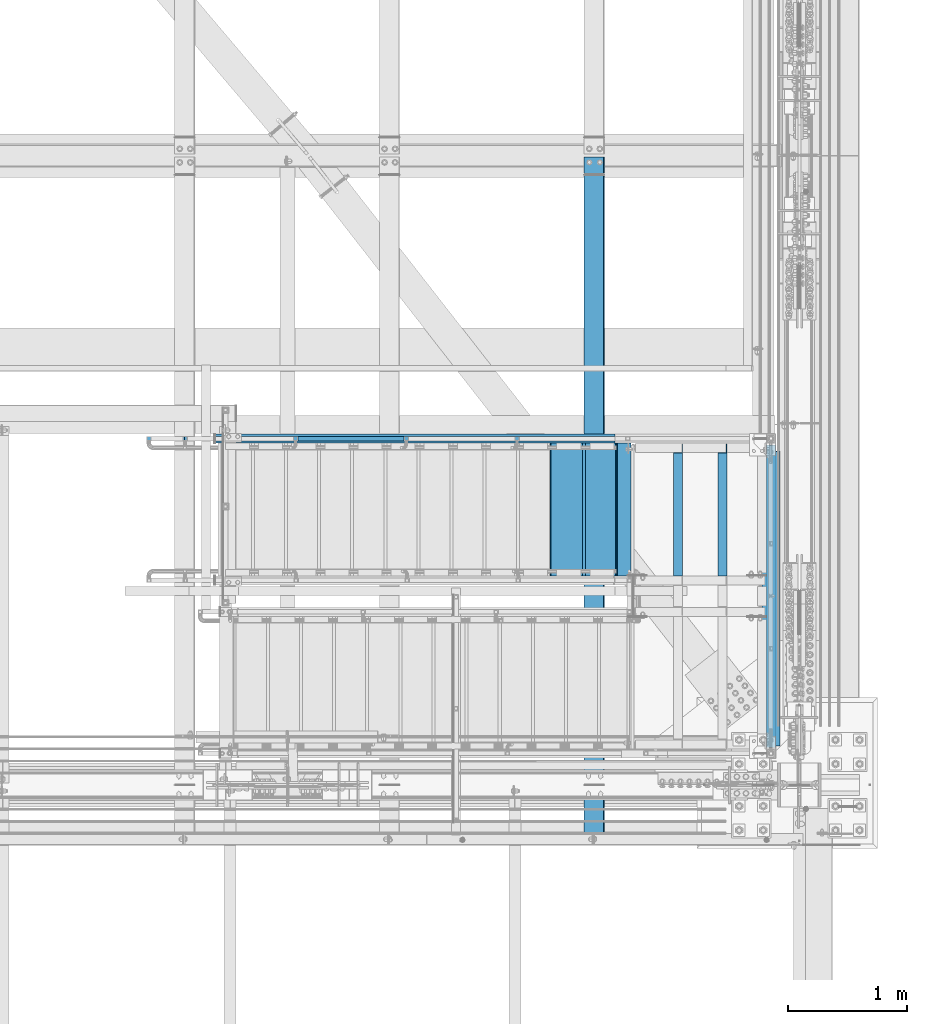
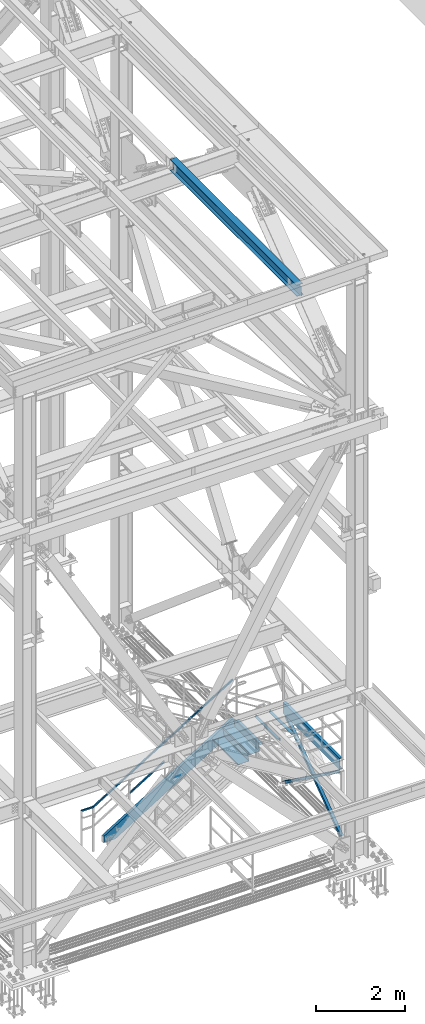
# One storey, part 1949 of 3843: 8 beams, 4 members, 8 elements without a shape of their own.
"""IFC2X3 building model written with IfcOpenShell, lengths in millimetres."""

from ifc_helpers import new_model, si_unit, frame, origin_with_axes, place, context, subcontext, project, spatial, faceted_brep, material, type_object, element, aggregate, save


model = new_model("IFC2X3")

# Units and contexts
model_context = context("Model", 3, precision=1e-05, world=origin_with_axes())
body_context = subcontext(model_context, "Body", "Model", "MODEL_VIEW")
ifc_project = project(units=[si_unit("LENGTHUNIT", "METRE", prefix="MILLI"), si_unit("AREAUNIT", "SQUARE_METRE"), si_unit("VOLUMEUNIT", "CUBIC_METRE"), si_unit("MASSUNIT", "GRAM", prefix="KILO"), si_unit("TIMEUNIT", "SECOND"), si_unit("PLANEANGLEUNIT", "RADIAN"), si_unit("SOLIDANGLEUNIT", "STERADIAN"), si_unit("THERMODYNAMICTEMPERATUREUNIT", "DEGREE_CELSIUS"), si_unit("LUMINOUSINTENSITYUNIT", "LUMEN")], contexts=[model_context])

# Site, building, storey
site_placement = place(None, origin_with_axes())
site = spatial("IfcSite", under=ifc_project, at=site_placement, CompositionType="ELEMENT")
building_placement = place(site_placement, origin_with_axes())
building = spatial("IfcBuilding", under=site, at=building_placement, Name="Undefined", CompositionType="ELEMENT")
storey_placement = place(building_placement, origin_with_axes())
storey = spatial("IfcBuildingStorey", under=building, at=storey_placement, Name="Undefined", CompositionType="ELEMENT", Elevation=0.0)

# Assembly, beam, member
assembly_1_placement = place(storey_placement, origin_with_axes())
assembly_1 = element("IfcElementAssembly", 1, at=assembly_1_placement, inside=storey, Name="RAIL", AssemblyPlace="NOTDEFINED", PredefinedType="RIGID_FRAME")
ifc_material_1 = material()
beam_type_1 = type_object("IfcBeamType", Name="HSS1-1/2X1-1/2X1/4", PredefinedType="NOTDEFINED")
beam_1_placement = place(assembly_1_placement, frame((84099.3999999465, 17919.7, 33781.9999999847), z_axis=(0.524097425775922, 0.0, -0.851658316635875), x_axis=(-0.851658316635875, 0.0, -0.524097425775922)))
beam_1 = element("IfcBeam", 2, at=beam_1_placement, type_object=beam_type_1, material=ifc_material_1, Name="RAIL", ObjectType="HSS1-1/2X1-1/2X1/4", context=body_context, shape_type="Brep", body=[
    faceted_brep([(-5.39195355401171, -19.0499992350015, -19.0499992349942), (5.39195347770146, -19.0499992350015, 19.0499992349796), (5.39195347770146, 19.0499992350015, 19.0499992349796), (-5.39195355401171, 19.0499992350015, -19.0499992349942), (3.59463559381402, 12.6999993300014, 12.6999993299833), (3.59463559381402, -12.6999993300014, 12.6999993299833), (-3.59463567009516, -12.6999993300014, -12.6999993299978), (-3.59463567009516, 12.6999993300014, -12.6999993299978), (4270.24785764143, -19.0499992349996, 19.0499992372643), (4270.24785764143, 19.0499992349996, 19.0499992372643), (4259.4639506097, 19.0499992349996, -19.049999232695), (4259.4639506097, -19.0499992349996, -19.049999232695), (4261.26126849362, -12.6999993299996, -12.6999993277132), (4261.26126849362, 12.6999993299996, -12.6999993277132), (4268.45053975753, 12.6999993299996, 12.6999993322825), (4268.45053975753, -12.6999993299996, 12.6999993322825), (4530.68139334727, 19.0499992350015, -185.9530417606), (4530.68139334727, -19.0499992350015, -185.9530417606), (4518.20132390667, -19.0499992350015, -133.536750079667), (4518.20132390667, 19.0499992350015, -133.536750079667), (4528.60138172143, -12.6999993300014, -177.216992926999), (4528.60138172143, 12.6999993300014, -177.216992926999), (4520.28133553253, 12.6999993300014, -142.27279891328), (4520.28133553253, -12.6999993300014, -142.27279891328)], [[[0, 1, 2, 3], [4, 5, 6, 7]], [[2, 1, 8, 9]], [[0, 3, 10, 11]], [[7, 6, 12, 13]], [[5, 4, 14, 15]], [[11, 10, 16, 17]], [[8, 1, 0, 11, 17, 18]], [[9, 8, 18, 19]], [[10, 3, 2, 9, 19, 16]], [[13, 12, 20, 21]], [[14, 4, 7, 13, 21, 22]], [[15, 14, 22, 23]], [[12, 6, 5, 15, 23, 20]], [[19, 18, 17, 16], [22, 21, 20, 23]]]),
])
member_type_1 = type_object("IfcMemberType", Name="HSS1-1/2X1-1/2X1/4", PredefinedType="NOTDEFINED")
member_1_placement = place(assembly_1_placement, frame((81400.649999991, 17919.7, 31587.830768766), z_axis=(-0.524097425775922, 0.0, 0.851658316635875), x_axis=(0.851658316635872, 0.0, 0.524097425775926)))
member_1 = element("IfcMember", 3, at=member_1_placement, type_object=member_type_1, material=ifc_material_1, Name="RAIL", ObjectType="HSS1-1/2X1-1/2X1/4", context=body_context, shape_type="Brep", body=[
    faceted_brep([(1085.39309424335, -19.0499999999993, 19.0499992355599), (1061.94694133186, -19.0499992350015, -19.0499992344103), (1061.94694133186, 19.0499992350015, -19.0499992344103), (1085.39309424335, 19.0499992350015, 19.0499992355599), (1081.48540199296, -12.6999993300014, 12.6999993305635), (1081.48540199296, 12.6999993300014, 12.6999993305635), (1065.85463358223, 12.6999993300014, -12.6999993294176), (1065.85463358223, -12.6999993300014, -12.6999993294176), (10.6450480494532, 19.0499992350015, -19.0499992349796), (34.091200960931, 19.0499992350015, 19.0499992349942), (34.091200960931, -19.0499992350015, 19.0499992349942), (10.6450480494532, -19.0499992350015, -19.0499992349796), (30.1835087105574, 12.6999993300014, 12.6999993299978), (30.1835087105574, -12.6999993300014, 12.6999993299978), (14.5527402998268, -12.6999993300014, -12.6999993299833), (14.5527402998268, 12.6999993300014, -12.6999993299833)], [[[0, 1, 2, 3], [4, 5, 6, 7]], [[8, 9, 3, 2]], [[9, 10, 0, 3]], [[10, 11, 1, 0]], [[11, 8, 2, 1]], [[11, 10, 9, 8], [12, 13, 14, 15]], [[14, 13, 4, 7]], [[15, 14, 7, 6]], [[12, 15, 6, 5]], [[13, 12, 5, 4]]]),
])
aggregate(assembly_1, [member_1, beam_1])

# Assembly, beams
assembly_2_placement = place(storey_placement, origin_with_axes())
assembly_2 = element("IfcElementAssembly", 4, at=assembly_2_placement, inside=storey, Name="STAIR", AssemblyPlace="NOTDEFINED", PredefinedType="RIGID_FRAME")
ifc_material_2 = material(Name="STEEL/ASTM A1011")
beam_type_2 = type_object("IfcBeamType", PredefinedType="NOTDEFINED")
beam_2_placement = place(assembly_2_placement, frame((84229.5749999933, 17322.7999999328, 32665.9875000002), z_axis=(0.0, -1.0, 0.0), x_axis=(-1.0, 0.0, 0.0)))
beam_2 = element("IfcBeam", 5, at=beam_2_placement, type_object=beam_type_2, material=ifc_material_2, Name="TREAD", context=body_context, shape_type="Brep", body=[
    faceted_brep([(0.0, -1.58750000000146, -558.799999999999), (0.0, -1.58750000000146, 558.799999999999), (0.0, 1.58750000000146, 558.799999999999), (0.0, 1.58750000000146, -558.799999999999), (118.955406534296, 1.58750000000509, 558.799999999999), (118.955406534296, 1.58750000000509, -558.799999999999), (116.251539361052, -1.58749999999782, -558.799999999999), (116.251539361052, -1.58749999999782, 558.799999999999), (124.953998182522, -35.5978063561452, 558.799999999999), (124.953998182522, -35.5978063561452, -558.799999999999), (121.81952036728, -36.1034483498916, 558.799999999999), (121.81952036728, -36.1034483498916, -558.799999999999)], [[[0, 1, 2, 3]], [[3, 2, 4, 5]], [[1, 0, 6, 7]], [[5, 4, 8, 9]], [[4, 2, 1, 7, 10, 8]], [[7, 6, 11, 10]], [[6, 0, 3, 5, 9, 11]], [[10, 11, 9, 8]]]),
])
beam_type_3 = type_object("IfcBeamType", PredefinedType="NOTDEFINED")
beam_3_placement = place(assembly_2_placement, frame((84124.8000000108, 17322.7999999328, 32713.6124999999), z_axis=(0.0, -1.0, 0.0), x_axis=(-1.0, 0.0, 0.0)))
beam_3 = element("IfcBeam", 6, at=beam_3_placement, type_object=beam_type_3, material=ifc_material_2, Name="TREAD", context=body_context, shape_type="Brep", body=[
    faceted_brep([(0.0, -1.58750000000146, -558.799999999999), (0.0, -1.58750000000146, 558.799999999999), (0.0, 1.58750000000146, 558.799999999999), (0.0, 1.58750000000146, -558.799999999999), (21.7215083258779, 1.58750000000146, 558.799999999999), (21.7215083258779, 1.58750000000146, -558.799999999999), (25.3999999999942, -1.58750000000146, -558.799999999999), (25.3999999999942, -1.58750000000146, 558.799999999999), (-11.1830371286633, 224.325961538467, 558.799999999999), (-11.1830371286633, 224.325961538467, -558.799999999999), (-7.50454545454704, 221.150961538464, -558.799999999999), (-7.50454545454704, 221.150961538464, 558.799999999999), (293.616962871325, 224.325961538467, 558.799999999999), (293.616962871325, 224.325961538467, -558.799999999999), (290.876539379024, 221.150961538464, -558.799999999999), (290.876539379024, 221.150961538464, 558.799999999999), (299.585432747743, 183.924011605752, 558.799999999999), (299.585432747743, 183.924011605752, -558.799999999999), (296.444520385252, 183.460013188564, 558.799999999999), (296.444520385252, 183.460013188564, -558.799999999999)], [[[0, 1, 2, 3]], [[3, 2, 4, 5]], [[1, 0, 6, 7]], [[5, 4, 8, 9]], [[7, 6, 10, 11]], [[9, 8, 12, 13]], [[11, 10, 14, 15]], [[13, 12, 16, 17]], [[12, 8, 4, 2, 1, 7, 11, 15, 18, 16]], [[15, 14, 19, 18]], [[14, 10, 6, 0, 3, 5, 9, 13, 17, 19]], [[18, 19, 17, 16]]]),
])
beam_4_placement = place(assembly_2_placement, frame((83845.4000000127, 17322.7999999318, 32541.6740384607), z_axis=(0.0, -1.0, 0.0), x_axis=(-1.0, 0.0, 0.0)))
beam_4 = element("IfcBeam", 7, at=beam_4_placement, type_object=beam_type_3, material=ifc_material_2, Name="TREAD", context=body_context, shape_type="Brep", body=[
    faceted_brep([(0.0, -1.58750000000146, -558.799999999999), (0.0, -1.58750000000146, 558.799999999999), (0.0, 1.58750000000146, 558.799999999999), (0.0, 1.58750000000146, -558.799999999999), (21.7215083258779, 1.58750000000146, 558.799999999999), (21.7215083258779, 1.58750000000146, -558.799999999999), (25.3999999999942, -1.58750000000146, -558.799999999999), (25.3999999999942, -1.58750000000146, 558.799999999999), (-11.1830371286633, 224.325961538467, 558.799999999999), (-11.1830371286633, 224.325961538467, -558.799999999999), (-7.50454545454704, 221.150961538464, -558.799999999999), (-7.50454545454704, 221.150961538464, 558.799999999999), (293.616962871325, 224.325961538467, 558.799999999999), (293.616962871325, 224.325961538467, -558.799999999999), (290.876539379024, 221.150961538464, -558.799999999999), (290.876539379024, 221.150961538464, 558.799999999999), (299.585432747743, 183.924011605752, 558.799999999999), (299.585432747743, 183.924011605752, -558.799999999999), (296.444520385252, 183.460013188564, 558.799999999999), (296.444520385252, 183.460013188564, -558.799999999999)], [[[0, 1, 2, 3]], [[3, 2, 4, 5]], [[1, 0, 6, 7]], [[5, 4, 8, 9]], [[7, 6, 10, 11]], [[9, 8, 12, 13]], [[11, 10, 14, 15]], [[13, 12, 16, 17]], [[12, 8, 4, 2, 1, 7, 11, 15, 18, 16]], [[15, 14, 19, 18]], [[14, 10, 6, 0, 3, 5, 9, 13, 17, 19]], [[18, 19, 17, 16]]]),
])

# Assembly, beam
assembly_3_placement = place(storey_placement, origin_with_axes())
assembly_3 = element("IfcElementAssembly", 8, at=assembly_3_placement, inside=storey, Name="STRINGER", AssemblyPlace="NOTDEFINED", PredefinedType="RIGID_FRAME")
ifc_material_3 = material(Name="STEEL/A36")
beam_type_4 = type_object("IfcBeamType", Name="C12X20.7", PredefinedType="NOTDEFINED")
beam_5_placement = place(assembly_3_placement, frame((85407.5000000149, 15227.3000000539, 32588.2), z_axis=(0.0, 0.0, 1.0), x_axis=(0.0, 1.0, 0.0)))
beam_5 = element("IfcBeam", 9, at=beam_5_placement, type_object=beam_type_4, material=ifc_material_3, Name="STRINGER", ObjectType="C12X20.7", context=body_context, shape_type="Brep", body=[
    faceted_brep([(88.8999999464759, 38.1000000000058, -152.400000000001), (88.8999999464759, 38.1000000000058, 152.400000000001), (2641.60000000041, 38.1000000000058, 152.400000000001), (2641.60000000041, 38.1000000000058, -152.400000000001), (88.8999999464759, -38.1000000000058, 152.400000000001), (2641.60000000041, -38.1000000000058, 152.400000000001), (88.8999999464759, -38.1000000000058, 146.047460000002), (2641.60000000041, -38.1000000000058, 146.047460000002), (88.8999999464759, 30.1625000000058, 134.6749275), (2641.60000000041, 30.1625000000058, 134.6749275), (88.8999999464759, 30.1625000000058, -134.6749275), (2641.60000000041, 30.1625000000058, -134.6749275), (88.8999999464759, -38.1000000000058, -146.047460000002), (2641.60000000041, -38.1000000000058, -146.047460000002), (88.8999999464759, -38.1000000000058, -152.400000000001), (2641.60000000041, -38.1000000000058, -152.400000000001)], [[[0, 1, 2, 3]], [[1, 4, 5, 2]], [[4, 6, 7, 5]], [[6, 8, 9, 7]], [[8, 10, 11, 9]], [[10, 12, 13, 11]], [[12, 14, 15, 13]], [[14, 0, 3, 15]], [[5, 7, 9, 11, 13, 15, 3, 2]], [[14, 12, 10, 8, 6, 4, 1, 0]]]),
])
aggregate(assembly_3, [beam_5])

# Member
member_type_2 = type_object("IfcMemberType", Name="C12X20.7", PredefinedType="NOTDEFINED")
member_2_placement = place(assembly_2_placement, frame((84172.0831760373, 17919.7000000062, 32610.8072725471), z_axis=(-0.524097425775922, 0.0, 0.851658316635875), x_axis=(-0.851658316635875, 0.0, -0.524097425775922)))
member_2 = element("IfcMember", 10, at=member_2_placement, type_object=member_type_2, material=ifc_material_3, Name="STAIR", ObjectType="C12X20.7", context=body_context, shape_type="Brep", body=[
    faceted_brep([(86.2712597135396, -38.0999999999985, -152.39999999988), (84.4732228755893, -38.0999999999985, -146.047459999883), (81.2543163632508, 30.1624999999985, -134.674927499889), (5.01694334564672, 30.1624999999985, 134.674927499867), (1.79803683332284, -38.0999999999985, 146.047459999862), (0.0, -38.0999999999985, 152.400000000001), (0.0, 38.0999999999985, 152.400000000001), (86.2712597135396, 38.0999999999985, -152.39999999988), (3793.78803882135, 38.0999999999985, -152.400000001866), (3793.78803882135, -38.0999999999985, -152.400000001866), (3804.11091631831, -38.0999999999985, -146.047460001873), (3822.59128162534, 30.1624999999985, -134.674927501905), (4049.06792565092, 30.1624999999985, 4.69531501628626), (3969.08047179269, 30.1624999999985, 134.674927497743), (3962.08199025219, -38.0999999999985, 146.047459997737), (3958.17273486643, -38.0999999999985, 152.399999997733), (3958.17273486643, 38.0999999999985, 152.399999997733), (4049.06792565092, 38.0999999999985, 4.69531501628626)], [[[0, 1, 2, 3, 4, 5, 6, 7]], [[0, 7, 8, 9]], [[1, 0, 9, 10]], [[2, 1, 10, 11]], [[3, 2, 11, 12, 13]], [[4, 3, 13, 14]], [[5, 4, 14, 15]], [[6, 5, 15, 16]], [[8, 7, 6, 16, 17]], [[11, 10, 9, 8, 17, 12]], [[16, 15, 14, 13, 12, 17]]]),
])

aggregate(assembly_2, [beam_2, beam_3, member_2, beam_4])

# Assembly, beam
assembly_4_placement = place(storey_placement, origin_with_axes())
assembly_4 = element("IfcElementAssembly", 11, at=assembly_4_placement, inside=storey, Name="BEAM", AssemblyPlace="NOTDEFINED", PredefinedType="RIGID_FRAME")
ifc_material_4 = material(Name="STEEL/A992")
beam_type_5 = type_object("IfcBeamType", Name="W12X26", PredefinedType="NOTDEFINED")
beam_6_placement = place(assembly_4_placement, frame((83918.3092623524, 14490.7000000001, 46575.5980897001), z_axis=(-0.0211520980073474, 0.0, 0.999776269347241), x_axis=(0.0, 1.0, 0.0)))
beam_6 = element("IfcBeam", 12, at=beam_6_placement, type_object=beam_type_5, material=ifc_material_4, Name="BEAM", ObjectType="W12X26", context=body_context, shape_type="Brep", body=[
    faceted_brep([(20.6374999998825, -3.17500000016298, -130.175000008305), (20.6374999998825, 3.1749999998865, -130.175000008305), (77.7875001906159, 3.1749999998865, -130.175000008334), (77.7875001906159, -3.17500000016298, -130.175000008334), (82.6475797086623, 3.1749999998865, -131.141729930918), (82.6475797086623, -3.17500000014843, -131.141729930918), (86.767756176816, 3.17499999987194, -133.894743831384), (86.767756176816, -3.17500000014843, -133.894743831377), (89.5207700772935, 3.17499999987194, -138.014920299524), (89.5207700772935, -3.17500000014843, -138.014920299516), (90.487499999881, -3.17500000014843, -142.874999817534), (90.487499999881, 3.17499999987194, -142.874999817541), (90.487499999881, 3.17499999987194, -146.049999999763), (90.487499999881, 82.5500000003231, -146.049999999828), (90.487499999881, 82.5500000003085, -155.574999999815), (90.487499999881, -82.5500000006286, -155.57499999967), (90.487499999881, -82.5500000006141, -146.04999999969), (90.487499999881, -3.17500000017753, -146.049999999756), (5803.89999999989, -82.5500000003231, 146.049999999843), (5803.89999999989, -82.5500000003085, 155.57499999983), (90.487499999881, -82.5500000003085, 155.574980215941), (90.487499999881, -82.5500000003231, 146.049999999843), (5803.89999999989, 82.5500000006141, 155.574999999684), (90.487499999881, 82.5500000006141, 155.574999999684), (5803.89999999989, 82.5500000006141, 146.049999999705), (90.487499999881, 82.5500000006141, 146.049999999705), (5803.89999999989, 3.17500000016298, 146.04999999977), (90.487499999881, 3.17500000016298, 146.04999999977), (77.7875001906159, -3.1749999998865, 130.174999990406), (77.7875001906159, 3.17500000014843, 130.174999990399), (20.6374999998825, 3.17500000014843, 130.174999990428), (20.6374999998825, -3.1749999998865, 130.174999990435), (82.6475797086623, -3.1749999998865, 131.14172991299), (82.6475797086623, 3.17500000013388, 131.14172991299), (86.767756176816, -3.1749999998865, 133.894743813456), (86.767756176816, 3.17500000014843, 133.894743813449), (89.5207700772935, -3.1749999998865, 138.014920281596), (89.5207700772935, 3.17500000016298, 138.014920281588), (90.487499999881, -3.1749999998865, 142.874999799613), (90.487499999881, 3.17500000016298, 142.874999799598), (90.487499999881, -3.1749999998865, 146.04999999977), (5803.89999999989, -3.1749999998865, 146.04999999977), (5803.89999999989, 3.17499999987194, -146.049999999763), (5803.89999999989, -3.17500000017753, -146.049999999756), (5803.89999999989, -82.5500000006141, -146.04999999969), (5803.89999999989, -82.5500000006286, -155.57499999967), (5803.89999999989, 82.5500000003085, -155.574999999815), (5803.89999999989, 82.5500000003231, -146.049999999828), (20.6374999998825, 3.1749999998865, -113.125000025924), (20.6374999998825, 3.17500000013388, 117.474999970342)], [[[0, 1, 2, 3]], [[3, 2, 4, 5]], [[5, 4, 6, 7]], [[7, 6, 8, 9]], [[10, 11, 12, 13, 14, 15, 16, 17]], [[9, 8, 11, 10]], [[18, 19, 20, 21]], [[19, 22, 23, 20]], [[22, 24, 25, 23]], [[24, 26, 27, 25]], [[28, 29, 30, 31]], [[32, 33, 29, 28]], [[34, 35, 33, 32]], [[36, 37, 35, 34]], [[38, 39, 37, 36]], [[20, 23, 25, 27, 39, 38, 40, 21]], [[41, 18, 21, 40]], [[42, 26, 24, 22, 19, 18, 41, 43, 44, 45, 46, 47]], [[44, 43, 17, 16]], [[45, 44, 16, 15]], [[46, 45, 15, 14]], [[47, 46, 14, 13]], [[42, 47, 13, 12]], [[6, 4, 2, 1, 48, 49, 30, 29, 33, 35, 37, 39, 27, 26, 42, 12, 11, 8]], [[31, 30, 49, 48, 1, 0]], [[43, 41, 40, 38, 36, 34, 32, 28, 31, 0, 3, 5, 7, 9, 10, 17]]]),
])
aggregate(assembly_4, [beam_6])

assembly_5_placement = place(storey_placement, origin_with_axes())
assembly_5 = element("IfcElementAssembly", 13, at=assembly_5_placement, inside=storey, Name="ANGLE", AssemblyPlace="NOTDEFINED", PredefinedType="RIGID_FRAME")
beam_type_6 = type_object("IfcBeamType", Name="L3X3X1/4", PredefinedType="NOTDEFINED")
beam_7_placement = place(assembly_5_placement, frame((84998.9833333383, 17881.6000000543, 32626.2999999982), z_axis=(-1.0, 0.0, 0.0), x_axis=(0.0, -1.0, 0.0)))
beam_7 = element("IfcBeam", 14, at=beam_7_placement, type_object=beam_type_6, material=ifc_material_3, Name="ANGLE", ObjectType="L3X3X1/4", context=body_context, shape_type="Brep", body=[
    faceted_brep([(6.34999999941647, -38.0999999999985, -31.75), (6.34999999999854, 19.0499999999956, -31.75), (6.34999999999854, 19.0499999999956, -38.0999999999985), (6.34999999941647, -38.0999999999985, -38.0999999999985), (19.0500000000029, 31.75, -31.75), (19.0499999999956, 31.7499999999927, -38.0999999999985), (76.1999999999971, 31.75, -31.75), (76.1999999999971, 31.7499999999927, -38.0999999999985), (82.5500000005923, 38.0999999999985, 38.0999999999985), (82.5499948264696, 38.0999999999458, -38.0999999999985), (76.1999999999971, 31.75, 38.0999999999985), (1117.60000005434, 31.7499999977736, 38.0999999999985), (1117.60000005434, 31.7499999977736, -31.75), (1117.6000000542, -38.100000002225, -31.75), (1117.6000000542, -38.100000002225, -38.0999999999985), (1117.60000005436, 38.0999999977794, -38.0999999999985), (1117.60000005436, 38.0999999977794, 38.0999999999985)], [[[0, 1, 2, 3]], [[4, 5, 2, 1]], [[6, 7, 5, 4]], [[8, 9, 7, 6, 10]], [[11, 12, 13, 14, 15, 16]], [[11, 16, 8, 10]], [[12, 11, 10, 6]], [[1, 0, 13, 12, 6, 4]], [[14, 13, 0, 3]], [[15, 14, 3, 2, 5, 7, 9]], [[16, 15, 9, 8]]]),
])
aggregate(assembly_5, [beam_7])

assembly_6_placement = place(storey_placement, origin_with_axes())
assembly_6 = element("IfcElementAssembly", 15, at=assembly_6_placement, inside=storey, Name="ANGLE", AssemblyPlace="NOTDEFINED", PredefinedType="RIGID_FRAME")
beam_8_placement = place(assembly_6_placement, frame((84626.45, 17881.6000000543, 32626.2999999982), z_axis=(-1.0, 0.0, 0.0), x_axis=(0.0, -1.0, 0.0)))
beam_8 = element("IfcBeam", 16, at=beam_8_placement, type_object=beam_type_6, material=ifc_material_3, Name="ANGLE", ObjectType="L3X3X1/4", context=body_context, shape_type="Brep", body=[
    faceted_brep([(6.34999999941647, -38.0999999999985, -31.75), (6.34999999999854, 19.0499999999956, -31.75), (6.34999999999854, 19.0499999999956, -38.0999999999985), (6.34999999941647, -38.0999999999985, -38.0999999999985), (19.0500000000029, 31.75, -31.75), (19.0499999999956, 31.7499999999927, -38.0999999999985), (76.1999999999971, 31.75, -31.75), (76.1999999999971, 31.7499999999927, -38.0999999999985), (82.5500000005923, 38.0999999999985, 38.0999999999985), (82.5499948264696, 38.0999999999458, -38.0999999999985), (76.1999999999971, 31.75, 38.0999999999985), (1117.60000005434, 31.7499999977736, 38.0999999999985), (1117.60000005434, 31.7499999977736, -31.75), (1117.6000000542, -38.100000002225, -31.75), (1117.6000000542, -38.100000002225, -38.0999999999985), (1117.60000005436, 38.0999999977794, -38.0999999999985), (1117.60000005436, 38.0999999977794, 38.0999999999985)], [[[0, 1, 2, 3]], [[4, 5, 2, 1]], [[6, 7, 5, 4]], [[8, 9, 7, 6, 10]], [[11, 12, 13, 14, 15, 16]], [[11, 16, 8, 10]], [[12, 11, 10, 6]], [[1, 0, 13, 12, 6, 4]], [[14, 13, 0, 3]], [[15, 14, 3, 2, 5, 7, 9]], [[16, 15, 9, 8]]]),
])
aggregate(assembly_6, [beam_8])

# Assembly, member
assembly_7_placement = place(storey_placement, origin_with_axes())
assembly_7 = element("IfcElementAssembly", 17, at=assembly_7_placement, inside=storey, Name="ANGLE", AssemblyPlace="NOTDEFINED", PredefinedType="RIGID_FRAME")
member_type_3 = type_object("IfcMemberType", Name="L3X3X3/8", PredefinedType="NOTDEFINED")
member_3_placement = place(assembly_7_placement, frame((85369.4000000298, 17919.6999998921, 30492.7000000001), z_axis=(-1.0, 0.0, 0.0), x_axis=(0.0, -0.808275935929298, 0.588803881948496)))
member_3 = element("IfcMember", 18, at=member_3_placement, type_object=member_type_3, material=ifc_material_3, Name="ANGLE", ObjectType="L3X3X3/8", context=body_context, shape_type="Brep", body=[
    faceted_brep([(106.316943888111, 38.1000000002459, -38.1000000000058), (106.316943888111, 38.1000000002459, 38.1000000000058), (3177.58633879714, 38.1000000076674, 38.1000000000058), (3177.58633879714, 38.1000000076674, -38.1000000000058), (106.316943888111, 28.5750000002517, 38.1000000000058), (3177.58633879714, 28.5750000076732, 38.1000000000058), (106.316943888111, 28.5750000002517, -28.5749999999971), (3177.58633879714, 28.5750000076732, -28.5749999999971), (106.316943888111, -38.0999999997366, -28.5749999999971), (3177.58633879714, -38.0999999923151, -28.5749999999971), (106.316943888111, -38.0999999997366, -38.1000000000058), (3177.58633879714, -38.0999999923151, -38.1000000000058)], [[[0, 1, 2, 3]], [[1, 4, 5, 2]], [[4, 6, 7, 5]], [[6, 8, 9, 7]], [[8, 10, 11, 9]], [[10, 0, 3, 11]], [[5, 7, 9, 11, 3, 2]], [[10, 8, 6, 4, 1, 0]]]),
])
aggregate(assembly_7, [member_3])

assembly_8_placement = place(storey_placement, origin_with_axes())
assembly_8 = element("IfcElementAssembly", 19, at=assembly_8_placement, inside=storey, Name="ANGLE", AssemblyPlace="NOTDEFINED", PredefinedType="RIGID_FRAME")
member_4_placement = place(assembly_8_placement, frame((85445.6000000299, 15265.3999992378, 30492.7), z_axis=(1.0, 0.0, 0.0), x_axis=(0.0, 0.808275936405213, 0.588803881295186)))
member_4 = element("IfcMember", 20, at=member_4_placement, type_object=member_type_3, material=ifc_material_3, Name="ANGLE", ObjectType="L3X3X3/8", context=body_context, shape_type="Brep", body=[
    faceted_brep([(106.316943888111, 38.1000000002459, -38.1000000000058), (106.316943888111, 38.1000000002459, 38.1000000000058), (3177.58633879714, 38.1000000076674, 38.1000000000058), (3177.58633879714, 38.1000000076674, -38.1000000000058), (106.316943888111, 28.5750000002517, 38.1000000000058), (3177.58633879714, 28.5750000076732, 38.1000000000058), (106.316943888111, 28.5750000002517, -28.5749999999971), (3177.58633879714, 28.5750000076732, -28.5749999999971), (106.316943888111, -38.0999999997366, -28.5749999999971), (3177.58633879714, -38.0999999923151, -28.5749999999971), (106.316943888111, -38.0999999997366, -38.1000000000058), (3177.58633879714, -38.0999999923151, -38.1000000000058)], [[[0, 1, 2, 3]], [[1, 4, 5, 2]], [[4, 6, 7, 5]], [[6, 8, 9, 7]], [[8, 10, 11, 9]], [[10, 0, 3, 11]], [[5, 7, 9, 11, 3, 2]], [[10, 8, 6, 4, 1, 0]]]),
])
aggregate(assembly_8, [member_4])

save(model, "model.ifc")
